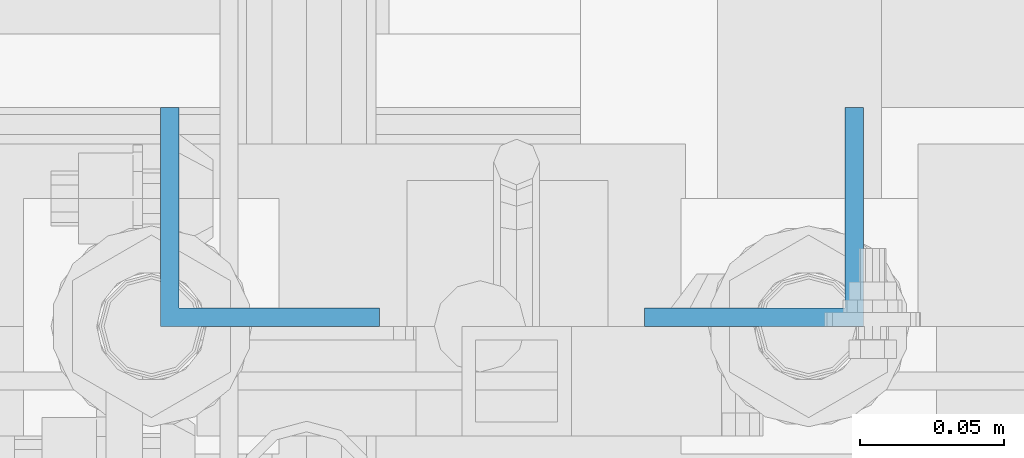
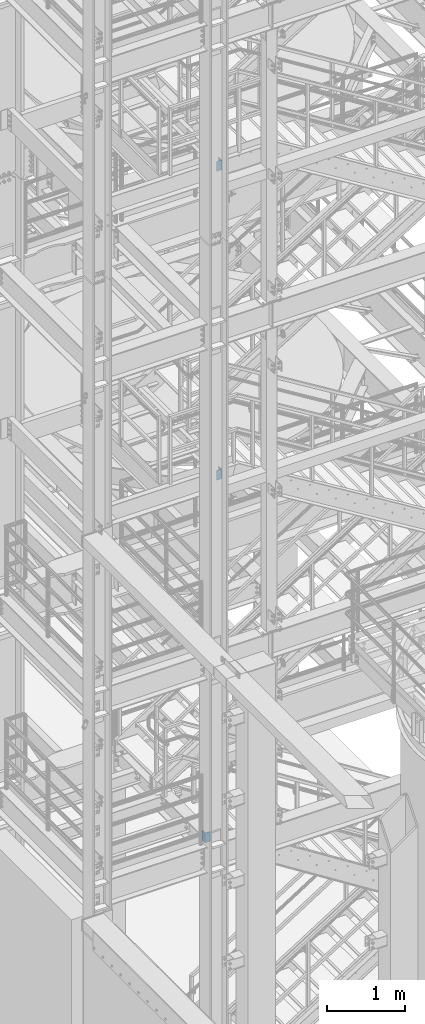
# One storey, part 803 of 1876: 3 columns, 3 elements without a shape of their own.
"""IFC2X3 building model written with IfcOpenShell, lengths in millimetres."""

import ifcopenshell
import ifcopenshell.guid

model = None  # the IFC model being written
_history = None  # IfcOwnerHistory: only IFC2X3 demands one
_inside = {}  # id of a spatial element -> (the spatial element, [elements in it])
_under = {}  # id of a project, library or spatial element -> (it, [spatial elements below it])
_declared = {}  # id of a project -> (the project, [libraries it declares])
_typed = {}  # id of a type object -> (the type object, [elements of that type])
_made_of = {}  # id of a material, layer set ... -> (it, [elements and type objects made of it])


def new_model(schema):
    """Start an empty IFC model of exactly this schema.

    Asked for "IFC4X3", IfcOpenShell would pick the latest addendum, in which some entities
    have other attributes; the version numbers below select the first issue.
    IFC2X3 requires an IfcOwnerHistory on every rooted entity: one is made here for all.
    """
    global model, _history
    if schema == "IFC4X3":
        model = ifcopenshell.file(schema_version=(4, 3, 0, 0))
    else:
        model = ifcopenshell.file(schema=schema)
    _inside.clear()
    _under.clear()
    _declared.clear()
    _typed.clear()
    _made_of.clear()
    _history = None
    if model.schema == "IFC2X3":
        org = make("IfcOrganization", Name="unknown")
        user = make(
            "IfcPersonAndOrganization",
            ThePerson=make("IfcPerson", FamilyName="unknown"),
            TheOrganization=org,
        )
        app = make(
            "IfcApplication",
            ApplicationDeveloper=org,
            Version="unknown",
            ApplicationFullName="unknown",
            ApplicationIdentifier="unknown",
        )
        _history = make(
            "IfcOwnerHistory",
            OwningUser=user,
            OwningApplication=app,
            ChangeAction="ADDED",
            CreationDate=0,
        )
    return model


def make(cls, **values):
    """One entity of the class cls with the attributes given. An attribute that is None is left unset."""
    return model.create_entity(
        cls, **{name: value for name, value in values.items() if value is not None}
    )


def rooted(cls, **values):
    """An entity with a GlobalId (a new one), such as an element, a storey or a relation."""
    return make(cls, GlobalId=ifcopenshell.guid.new(), OwnerHistory=_history, **values)


def si_unit(unit_type, name, prefix=None):
    """IfcSIUnit, for example si_unit("LENGTHUNIT", "METRE", prefix="MILLI")."""
    return make("IfcSIUnit", UnitType=unit_type, Prefix=prefix, Name=name)


def assignment(units):
    """IfcUnitAssignment: the units of a project."""
    return None if units is None else make("IfcUnitAssignment", Units=units)


def point(xyz):
    """IfcCartesianPoint."""
    return None if xyz is None else make("IfcCartesianPoint", Coordinates=xyz)


def direction(xyz):
    """IfcDirection."""
    return None if xyz is None else make("IfcDirection", DirectionRatios=xyz)


def frame(location, z_axis=None, x_axis=None):
    """IfcAxis2Placement3D, a coordinate frame: its origin and axes. An axis left out is left unset."""
    return make(
        "IfcAxis2Placement3D",
        Location=point(location),
        Axis=direction(z_axis),
        RefDirection=direction(x_axis),
    )


def origin_with_axes():
    """The frame at (0, 0, 0) with the z axis (0, 0, 1) and the x axis (1, 0, 0) written out."""
    return frame((0.0, 0.0, 0.0), z_axis=(0.0, 0.0, 1.0), x_axis=(1.0, 0.0, 0.0))


def place(relative_to, where):
    """IfcLocalPlacement: puts the frame where relative to a parent placement (None: the world)."""
    return make(
        "IfcLocalPlacement", PlacementRelTo=relative_to, RelativePlacement=where
    )


def context(
    kind, dimensions, precision=None, world=None, true_north=None, identifier=None
):
    """IfcGeometricRepresentationContext, for example the 3D "Model" context."""
    return make(
        "IfcGeometricRepresentationContext",
        ContextIdentifier=identifier,
        ContextType=kind,
        CoordinateSpaceDimension=dimensions,
        Precision=precision,
        WorldCoordinateSystem=world,
        TrueNorth=true_north,
    )


def subcontext(parent, identifier, kind, view, scale=None):
    """IfcGeometricRepresentationSubContext, for example "Body" below "Model"."""
    return make(
        "IfcGeometricRepresentationSubContext",
        ContextIdentifier=identifier,
        ContextType=kind,
        ParentContext=parent,
        TargetScale=scale,
        TargetView=view,
    )


def project(units=None, contexts=None):
    """IfcProject with its units and contexts."""
    return rooted(
        "IfcProject",
        Name="project",
        RepresentationContexts=contexts,
        UnitsInContext=assignment(units),
    )


def spatial(cls, under=None, at=None, **own):
    """A site, building, storey or space (cls), placed at a placement, below another one or the project."""
    s = rooted(cls, ObjectPlacement=at, **own)
    if under is not None:
        _under.setdefault(under.id(), (under, []))[1].append(s)
    return s


def faces_of(points, faces, orient=None, outer=None):
    """IfcFace entities. A face is a list of loops; a loop is a list of indices into points, from 0.

    orient and outer hold one flag for each loop. By default every Orientation is true, the
    first loop of a face is its IfcFaceOuterBound and the others are IfcFaceBound.
    """
    made = []
    for i, loops in enumerate(faces):
        bounds = []
        for j, loop in enumerate(loops):
            is_outer = j == 0 if outer is None else outer[i][j]
            bounds.append(
                make(
                    "IfcFaceOuterBound" if is_outer else "IfcFaceBound",
                    Bound=make("IfcPolyLoop", Polygon=[points[k] for k in loop]),
                    Orientation=True if orient is None else orient[i][j],
                )
            )
        made.append(make("IfcFace", Bounds=bounds))
    return made


def faceted_brep(points, faces, orient=None, outer=None, voids=None):
    """IfcFacetedBrep: a solid bounded by flat faces; with voids (closed shells), ...WithVoids."""
    shared = [point(p) for p in points]
    hull = make("IfcClosedShell", CfsFaces=faces_of(shared, faces, orient, outer))
    if voids is None:
        return make("IfcFacetedBrep", Outer=hull)
    return make(
        "IfcFacetedBrepWithVoids",
        Outer=hull,
        Voids=[
            make(cls, CfsFaces=faces_of(shared, fs, o, b)) for cls, fs, o, b in voids
        ],
    )


def shape(context_of_items, identifier, shape_type, items):
    """IfcShapeRepresentation: the items that make up one representation, for example the "Body"."""
    return make(
        "IfcShapeRepresentation",
        ContextOfItems=context_of_items,
        RepresentationIdentifier=identifier,
        RepresentationType=shape_type,
        Items=items,
    )


def material(Name=None, Category=None):
    """IfcMaterial."""
    return make("IfcMaterial", Name=Name, Category=Category)


def made_of(thing, what):
    """Note that an element or type object is made of a material, layer set ...; save() writes the relation."""
    if what is not None:
        _made_of.setdefault(what.id(), (what, []))[1].append(thing)
    return thing


def type_object(cls, material=None, **own):
    """A type object (cls), such as IfcWallType, which elements share."""
    return made_of(rooted(cls, **own), material)


def element(
    cls,
    number,
    at=None,
    inside=None,
    cuts=None,
    type_object=None,
    material=None,
    context=None,
    identifier="Body",
    shape_type=None,
    held_by="IfcProductDefinitionShape",
    body=None,
    shapes=None,
    **own,
):
    """One element of the class cls, such as IfcWall. Its Tag is "e" and its number.

    at: its placement. inside: the storey or other place that contains it. cuts: it is an
    opening in that element (IfcRelVoidsElement). A single representation is given by context,
    identifier, shape_type and body (its items); several are given by shapes. held_by: the class
    of the entity that holds the representations. save() writes the other relations.
    """
    e = rooted(cls, Tag="e%d" % number, ObjectPlacement=at, **own)
    if body is not None:
        shapes = [shape(context, identifier, shape_type, body)]
    if shapes is not None:
        e.Representation = make(held_by, Representations=shapes)
    if inside is not None:
        _inside.setdefault(inside.id(), (inside, []))[1].append(e)
    if cuts is not None:
        rooted(
            "IfcRelVoidsElement", RelatingBuildingElement=cuts, RelatedOpeningElement=e
        )
    if type_object is not None:
        _typed.setdefault(type_object.id(), (type_object, []))[1].append(e)
    return made_of(e, material)


def aggregate(whole, parts):
    """IfcRelAggregates: a whole, such as a stair, and the parts it consists of."""
    return rooted("IfcRelAggregates", RelatingObject=whole, RelatedObjects=parts)


def save(model, path):
    """Write the relations noted so far, then the file.

    IfcRelAggregates (storeys below a building ...), IfcRelContainedInSpatialStructure (elements
    in a storey), IfcRelDefinesByType, IfcRelAssociatesMaterial and IfcRelDeclares: one each for
    every whole, place, type object, material and project.
    """
    for whole, parts in _under.values():
        aggregate(whole, parts)
    for where, things in _inside.values():
        rooted(
            "IfcRelContainedInSpatialStructure",
            RelatedElements=things,
            RelatingStructure=where,
        )
    for kind, things in _typed.values():
        rooted("IfcRelDefinesByType", RelatedObjects=things, RelatingType=kind)
    for what, things in _made_of.values():
        rooted("IfcRelAssociatesMaterial", RelatedObjects=things, RelatingMaterial=what)
    for by, libraries in _declared.values():
        rooted("IfcRelDeclares", RelatingContext=by, RelatedDefinitions=libraries)
    model.write(path)


model = new_model("IFC2X3")

# Units and contexts
model_context = context("Model", 3, precision=1e-05, world=origin_with_axes())
body_context = subcontext(model_context, "Body", "Model", "MODEL_VIEW")
ifc_project = project(units=[si_unit("LENGTHUNIT", "METRE", prefix="MILLI"), si_unit("AREAUNIT", "SQUARE_METRE"), si_unit("VOLUMEUNIT", "CUBIC_METRE"), si_unit("MASSUNIT", "GRAM", prefix="KILO"), si_unit("TIMEUNIT", "SECOND"), si_unit("PLANEANGLEUNIT", "RADIAN"), si_unit("SOLIDANGLEUNIT", "STERADIAN"), si_unit("THERMODYNAMICTEMPERATUREUNIT", "DEGREE_CELSIUS"), si_unit("LUMINOUSINTENSITYUNIT", "LUMEN")], contexts=[model_context])

# Site, building, storey
site_placement = place(None, origin_with_axes())
site = spatial("IfcSite", under=ifc_project, at=site_placement, CompositionType="ELEMENT")
building_placement = place(site_placement, origin_with_axes())
building = spatial("IfcBuilding", under=site, at=building_placement, Name="Undefined", CompositionType="ELEMENT")
storey_placement = place(building_placement, origin_with_axes())
storey = spatial("IfcBuildingStorey", under=building, at=storey_placement, Name="Undefined", CompositionType="ELEMENT", Elevation=0.0)

# Assembly, column
assembly_1_placement = place(storey_placement, origin_with_axes())
assembly_1 = element("IfcElementAssembly", 1, at=assembly_1_placement, inside=storey, Name="STRINGER", AssemblyPlace="NOTDEFINED", PredefinedType="RIGID_FRAME")
ifc_material = material(Name="STEEL/A36")
column_type = type_object("IfcColumnType", Name="L3X3X1/4", PredefinedType="NOTDEFINED")
column_1_placement = place(assembly_1_placement, frame((1936.75, -6845.30000114557, 15385.2867791615), z_axis=(0.0, 1.0, 0.0), x_axis=(0.0, 0.0, 1.0)))
column_1 = element("IfcColumn", 2, at=column_1_placement, type_object=column_type, material=ifc_material, Name="ANGLE", ObjectType="L3X3X1/4", context=body_context, shape_type="Brep", body=[
    faceted_brep([(0.0, 38.1000000000004, -38.1), (0.0, 38.1000000000004, 38.1), (152.4, 38.1000000000004, 38.1), (152.4, 38.1000000000004, -38.1), (0.0, 31.75, 38.1000000000004), (152.4, 31.75, 38.0999999999999), (0.0, 31.75, -31.75), (152.4, 31.75, -31.75), (0.0, -38.1000000000004, -31.75), (152.4, -38.1000000000004, -31.75), (0.0, -38.1000000000004, -38.1), (152.4, -38.1000000000004, -38.1)], [[[0, 1, 2, 3]], [[1, 4, 5, 2]], [[4, 6, 7, 5]], [[6, 8, 9, 7]], [[8, 10, 11, 9]], [[10, 0, 3, 11]], [[5, 7, 9, 11, 3, 2]], [[10, 8, 6, 4, 1, 0]]]),
])
aggregate(assembly_1, [column_1])

assembly_2_placement = place(storey_placement, origin_with_axes())
assembly_2 = element("IfcElementAssembly", 3, at=assembly_2_placement, inside=storey, Name="STRINGER", AssemblyPlace="NOTDEFINED", PredefinedType="RIGID_FRAME")
column_2_placement = place(assembly_2_placement, frame((1936.75000034225, -6845.30000114946, 10556.875), z_axis=(0.0, 1.0, 0.0), x_axis=(0.0, 0.0, 1.0)))
column_2 = element("IfcColumn", 4, at=column_2_placement, type_object=column_type, material=ifc_material, Name="ANGLE", ObjectType="L3X3X1/4", context=body_context, shape_type="Brep", body=[
    faceted_brep([(0.0, 38.1000000000004, -38.1), (0.0, 38.1000000000004, 38.1), (152.4, 38.1000000000004, 38.1), (152.4, 38.1000000000004, -38.1), (0.0, 31.75, 38.1000000000004), (152.4, 31.75, 38.0999999999999), (0.0, 31.75, -31.75), (152.4, 31.75, -31.75), (0.0, -38.1000000000004, -31.75), (152.4, -38.1000000000004, -31.75), (0.0, -38.1000000000004, -38.1), (152.4, -38.1000000000004, -38.1)], [[[0, 1, 2, 3]], [[1, 4, 5, 2]], [[4, 6, 7, 5]], [[6, 8, 9, 7]], [[8, 10, 11, 9]], [[10, 0, 3, 11]], [[5, 7, 9, 11, 3, 2]], [[10, 8, 6, 4, 1, 0]]]),
])
aggregate(assembly_2, [column_2])

assembly_3_placement = place(storey_placement, origin_with_axes())
assembly_3 = element("IfcElementAssembly", 5, at=assembly_3_placement, inside=storey, Name="STRINGER", AssemblyPlace="NOTDEFINED", PredefinedType="RIGID_FRAME")
column_3_placement = place(assembly_3_placement, frame((1768.475, -6845.30000113476, 4949.82499999939), z_axis=(1.0, 0.0, 0.0), x_axis=(0.0, 0.0, 1.0)))
column_3 = element("IfcColumn", 6, at=column_3_placement, type_object=column_type, material=ifc_material, Name="ANGLE", ObjectType="L3X3X1/4", context=body_context, shape_type="Brep", body=[
    faceted_brep([(0.0, 38.1000000000004, -38.1), (0.0, 38.1000000000004, 38.1), (152.4, 38.1000000000004, 38.1), (152.4, 38.1000000000004, -38.1), (0.0, 31.75, 38.1000000000004), (152.4, 31.75, 38.0999999999999), (0.0, 31.75, -31.75), (152.4, 31.75, -31.75), (0.0, -38.1000000000004, -31.75), (152.4, -38.1000000000004, -31.75), (0.0, -38.1000000000004, -38.1), (152.4, -38.1000000000004, -38.1)], [[[0, 1, 2, 3]], [[1, 4, 5, 2]], [[4, 6, 7, 5]], [[6, 8, 9, 7]], [[8, 10, 11, 9]], [[10, 0, 3, 11]], [[5, 7, 9, 11, 3, 2]], [[10, 8, 6, 4, 1, 0]]]),
])
aggregate(assembly_3, [column_3])

save(model, "model.ifc")
